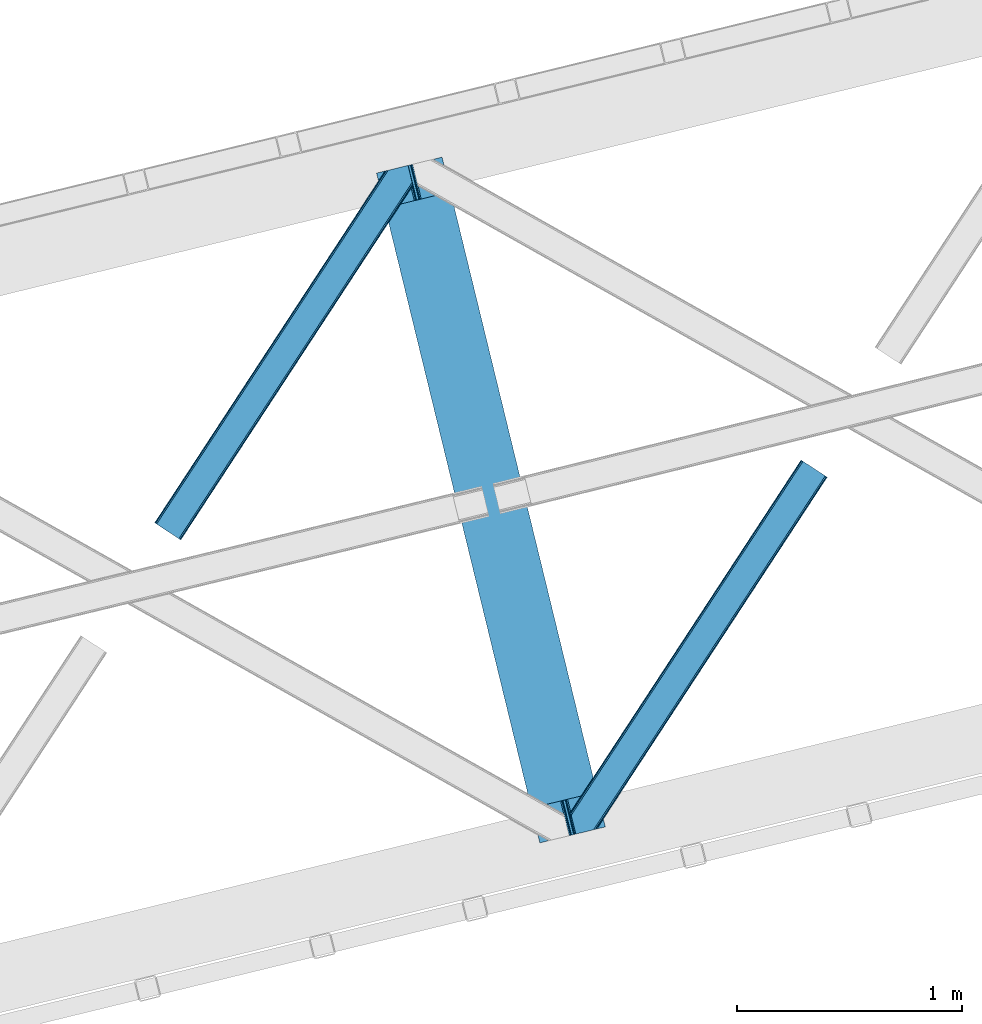
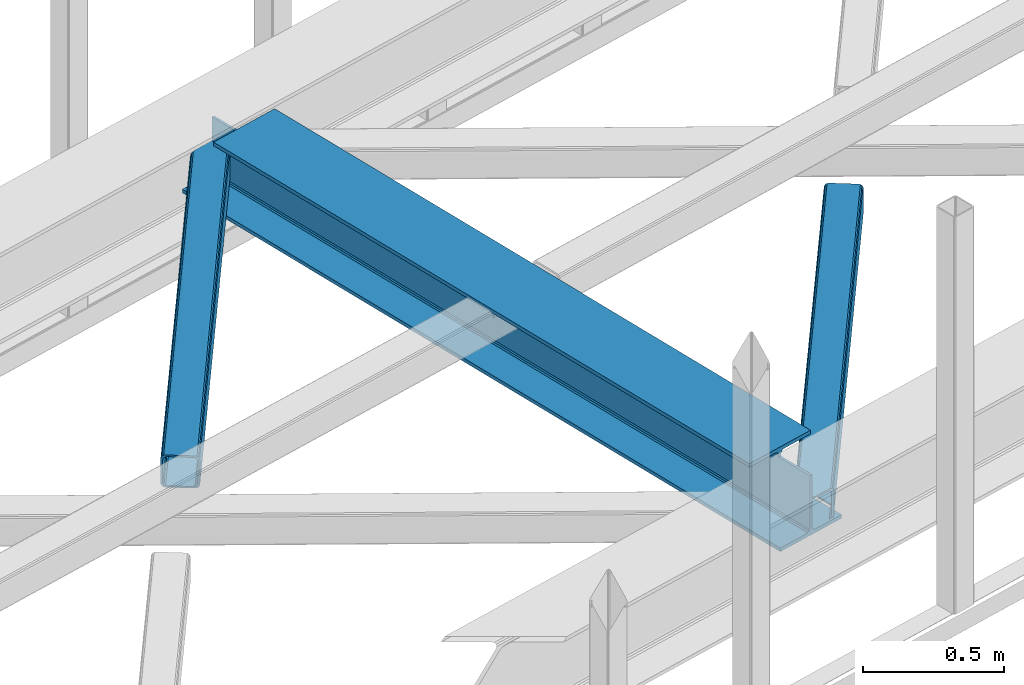
# One storey, part 33 of 67: 2 members, 1 beam.
"""IFC4 building model written with IfcOpenShell, lengths in millimetres."""

from ifc_helpers import new_model, entity, si_unit, converted_unit, derived_unit, direction, frame, origin, place, context, subcontext, project, spatial, triangles, polygons, material, type_object, element, save


model = new_model("IFC4")

# Units and contexts
model_context = context("Model", 3, precision=0.01, world=origin(), true_north=direction((6.12303176911189e-17, 1.0)))
plan_context = context("Plan", 3, precision=0.01, world=origin(), true_north=direction((6.12303176911189e-17, 1.0)))
body_context = subcontext(model_context, "Body", "Model", "MODEL_VIEW")
ifc_project = project(units=[si_unit("LENGTHUNIT", "METRE", prefix="MILLI"), si_unit("AREAUNIT", "SQUARE_METRE"), si_unit("VOLUMEUNIT", "CUBIC_METRE"), converted_unit("PLANEANGLEUNIT", "DEGREE", entity("IfcRatioMeasure", 0.0174532925199433), si_unit("PLANEANGLEUNIT", "RADIAN"), dimensions=[0, 0, 0, 0, 0, 0, 0]), si_unit("MASSUNIT", "GRAM", prefix="KILO"), derived_unit("MASSDENSITYUNIT", [(si_unit("MASSUNIT", "GRAM", prefix="KILO"), 1), (si_unit("LENGTHUNIT", "METRE"), -3)]), derived_unit("MOMENTOFINERTIAUNIT", [(si_unit("LENGTHUNIT", "METRE"), 4)]), si_unit("TIMEUNIT", "SECOND"), si_unit("FREQUENCYUNIT", "HERTZ"), si_unit("THERMODYNAMICTEMPERATUREUNIT", "DEGREE_CELSIUS"), derived_unit("THERMALTRANSMITTANCEUNIT", [(si_unit("MASSUNIT", "GRAM", prefix="KILO"), 1), (si_unit("THERMODYNAMICTEMPERATUREUNIT", "KELVIN"), -1), (si_unit("TIMEUNIT", "SECOND"), -3)]), derived_unit("VOLUMETRICFLOWRATEUNIT", [(si_unit("LENGTHUNIT", "METRE"), 3), (si_unit("TIMEUNIT", "SECOND"), -1)]), derived_unit("MASSFLOWRATEUNIT", [(si_unit("MASSUNIT", "GRAM", prefix="KILO"), 1), (si_unit("TIMEUNIT", "SECOND"), -1)]), derived_unit("ROTATIONALFREQUENCYUNIT", [(si_unit("TIMEUNIT", "SECOND"), -1)]), si_unit("ELECTRICCURRENTUNIT", "AMPERE"), si_unit("ELECTRICVOLTAGEUNIT", "VOLT"), si_unit("POWERUNIT", "WATT"), si_unit("FORCEUNIT", "NEWTON", prefix="KILO"), si_unit("ILLUMINANCEUNIT", "LUX"), si_unit("LUMINOUSFLUXUNIT", "LUMEN"), si_unit("LUMINOUSINTENSITYUNIT", "CANDELA"), derived_unit("USERDEFINED", [(si_unit("MASSUNIT", "GRAM", prefix="KILO"), -1), (si_unit("LENGTHUNIT", "METRE"), -2), (si_unit("TIMEUNIT", "SECOND"), 3), (si_unit("LUMINOUSFLUXUNIT", "LUMEN"), 1)]), derived_unit("LINEARVELOCITYUNIT", [(si_unit("LENGTHUNIT", "METRE"), 1), (si_unit("TIMEUNIT", "SECOND"), -1)]), si_unit("PRESSUREUNIT", "PASCAL"), derived_unit("USERDEFINED", [(si_unit("LENGTHUNIT", "METRE"), -2), (si_unit("MASSUNIT", "GRAM", prefix="KILO"), 1), (si_unit("TIMEUNIT", "SECOND"), -2)]), derived_unit("LINEARFORCEUNIT", [(si_unit("MASSUNIT", "GRAM", prefix="KILO"), 1), (si_unit("LENGTHUNIT", "METRE"), 1), (si_unit("TIMEUNIT", "SECOND"), -2), (si_unit("LENGTHUNIT", "METRE"), -1)]), derived_unit("PLANARFORCEUNIT", [(si_unit("MASSUNIT", "GRAM", prefix="KILO"), 1), (si_unit("LENGTHUNIT", "METRE"), 1), (si_unit("TIMEUNIT", "SECOND"), -2), (si_unit("LENGTHUNIT", "METRE"), -2)])], contexts=[model_context, plan_context])

# Site, building, storey
site_placement = place(None, origin())
site = spatial("IfcSite", under=ifc_project, at=site_placement, CompositionType="ELEMENT")
building_placement = place(site_placement, origin())
building = spatial("IfcBuilding", under=site, at=building_placement, CompositionType="ELEMENT")
storey_placement = place(building_placement, frame((0.0, 0.0, 19800.0)))
storey = spatial("IfcBuildingStorey", under=building, at=storey_placement, CompositionType="ELEMENT", Elevation=19800.0)

# Beam
ifc_material = material(Name="Metal painted (White)")
beam_type = type_object("IfcBeamType", PredefinedType="BEAM")
beam_placement = place(storey_placement, frame((-36668.6903596442, 8856.54799038463, 3808.0)))
element("IfcBeam", 1, at=beam_placement, inside=storey, type_object=beam_type, material=ifc_material, ObjectType="Steel Beam", PredefinedType="BEAM", context=body_context, shape_type="Tessellation", body=[
    polygons([(1018.16648378329, 71.0478278970989, 15.5000000000051), (1018.16648378329, 71.047827897101, 0.0), (291.465617442442, 3052.25531830421, 0.0), (291.465617442442, 3052.25531830421, 15.5000000000051), (894.779372399325, 40.9709140873259, 15.5000000000051), (168.078506058478, 3022.17840449444, 15.5000000000051), (888.087028625366, 39.339584488821, 16.8701684148028), (161.386162284515, 3020.54707489593, 16.8701684148028), (882.413533524746, 37.9566100336497, 20.7720779386478), (155.7126671839, 3019.16410044076, 20.7720779386478), (878.622625296176, 37.0325360459173, 26.6116982174338), (151.921758955325, 3018.24002645303, 26.6116982174338), (877.291435352775, 36.7080444135018, 33.500000000001), (150.590569011928, 3017.91553482061, 33.500000000001), (140.875048430514, 3015.54727389071, 33.500000000001), (140.875048430518, 3015.54727389071, 259.000000000006), (150.590569011928, 3017.91553482061, 259.000000000006), (0.0, 2981.20749040711, 4.33146851719357e-12), (0.0, 2981.20749040711, 15.5000000000051), (123.387111383968, 3011.28440421688, 15.5000000000051), (130.079455157922, 3012.91573381539, 16.8701684148028), (135.752950258546, 3014.29870827056, 20.7720779386478), (139.543858487122, 3015.22278225829, 26.6116982174338), (877.291435352775, 36.7080444135018, 259.000000000006), (867.57591477136, 34.3397834836003, 259.000000000006), (867.57591477136, 34.3397834835981, 33.500000000001), (866.244724827968, 34.0152918511837, 26.6116982174338), (862.453816599393, 33.0912178634492, 20.7720779386478), (856.780321498777, 31.7082434082767, 16.8701684148028), (850.087977724815, 30.076913809773, 15.5000000000051), (726.700866340847, 0.0, 15.5000000000051), (726.700866340847, 0.0, 4.33146851719357e-12), (839.723099725409, 190.827961666225, 259.069792599954), (188.068298227652, 2864.16742161973, 259.000000000006), (188.291691329497, 2863.25097721476, 259.617303331129), (188.304080173126, 2863.20015298098, 266.500003008253), (839.577920935828, 191.423439609248, 266.500002998871), (839.578271056576, 191.422003304514, 260.000004007593), (830.098162489501, 188.087889491629, 259.00634317046), (829.874792453792, 189.004341089458, 259.617303331129), (829.862403610162, 189.055165323231, 266.500003008253), (178.588562847465, 2860.83187869496, 266.500002998871), (178.588212726713, 2860.8333149997, 260.000004007593), (178.443407068373, 2861.42736381349, 259.076120467494), (178.352777646233, 2861.79916068982, 259.000000000006), (840.909408805751, 191.746709053933, 273.388305639792), (844.699685394443, 192.673374225847, 279.227924098781), (850.372756341981, 194.058088689524, 283.129832400619), (857.064948023115, 195.690042220337, 284.500000377228), (980.451976710954, 225.767295275449, 284.500000138975), (980.450306904298, 225.77414534418, 299.999995328161), (688.984884807028, 154.725516080138, 299.999995890966), (688.98655461368, 154.718666011407, 284.500000701776), (812.373583301528, 184.795919066517, 284.500000463524), (819.066070197671, 186.426661533095, 283.129832461069), (824.739981846423, 187.80792717762, 279.227924137327), (828.531516633419, 188.729430826919, 273.388305663689), (177.257074977538, 2860.50860925028, 273.388305639792), (173.46679838885, 2859.58194407836, 279.227924098781), (167.793727441316, 2858.19722961469, 283.129832400619), (161.101535760182, 2856.56527608387, 284.500000377228), (37.7145070723341, 2826.48802302876, 284.500000138975), (37.7161768789945, 2826.48117296003, 299.999995328161), (329.18159897626, 2897.52980222407, 299.999995890962), (329.179929169609, 2897.5366522928, 284.500000701776), (205.79290048176, 2867.45939923769, 284.500000463524), (199.100413585622, 2865.82865677111, 283.129832461069), (193.426501936866, 2864.44739112659, 279.227924137327), (189.63496714987, 2863.52588747729, 273.388305663689)], [[[1, 2, 3, 4]], [[5, 1, 4, 6]], [[7, 5, 6, 8]], [[9, 7, 8, 10]], [[11, 9, 10, 12]], [[13, 11, 12, 14]], [[15, 16, 17, 14, 12, 10, 8, 6, 4, 3, 18, 19, 20, 21, 22, 23]], [[13, 24, 25, 26, 27, 28, 29, 30, 31, 32, 2, 1, 5, 7, 9, 11]], [[2, 32, 18, 3]], [[32, 31, 19, 18]], [[31, 30, 20, 19]], [[27, 26, 15, 23]], [[28, 27, 23, 22]], [[29, 28, 22, 21]], [[30, 29, 21, 20]], [[33, 24, 13, 14, 17, 34, 35, 36, 37, 38]], [[25, 39, 40, 41, 42, 43, 44, 16, 15, 26]], [[39, 25, 24, 33]], [[45, 34, 17, 16]], [[41, 40, 38, 37, 46, 47, 48, 49, 50, 51, 52, 53, 54, 55, 56, 57]], [[42, 58, 59, 60, 61, 62, 63, 64, 65, 66, 67, 68, 69, 36, 35, 43]], [[46, 37, 36, 69]], [[47, 46, 69, 68]], [[48, 47, 68, 67]], [[49, 48, 67, 66]], [[50, 49, 66, 65]], [[51, 50, 65, 64]], [[52, 51, 64, 63]], [[53, 52, 63, 62]], [[54, 53, 62, 61]], [[55, 54, 61, 60]], [[56, 55, 60, 59]], [[57, 56, 59, 58]], [[41, 57, 58, 42]]], closed=False),
])

# Members
member_type_1 = type_object("IfcMemberType", PredefinedType="BRACE")
member_1_placement = place(storey_placement, frame((-37656.9014648438, 10204.5515441895, 3823.99987792968)))
element("IfcMember", 2, at=member_1_placement, inside=storey, type_object=member_type_1, ObjectType="Steel Horizontal Brace", PredefinedType="BRACE", context=body_context, shape_type="Tessellation", body=[
    triangles([(994.774163818358, 1564.02662658691, 0.0), (1028.82324829102, 1424.34678039551, 0.0), (14.643292236331, 67.1040435791019, 0.0), (102.486767578128, 9.58662414550781, 0.0), (1.1162109375, 75.9604797363281, 10.8039916992202), (0.0, 76.6895050048824, 17.5012573242202), (1025.02813110351, 1642.17883300781, 17.5012573242202), (4.29043579101563, 73.8826995849613, 5.12526855468968), (990.476751708986, 1585.87645568848, 9.49942016601563), (990.046545410158, 1584.44747314453, 8.74132690429906), (989.90701904297, 1583.99168701172, 8.49948120117188), (990.762780761717, 1580.48841247559, 5.12526855468968), (1027.31171264649, 1642.73461303711, 10.8691040039084), (1027.78377685547, 1642.84972229004, 9.49942016601563), (992.602203369141, 1572.93538513184, 1.33247680664135), (9.04130859374709, 70.7724243164066, 1.33247680664135), (1025.02813110351, 1642.17883300781, 122.499499511719), (0.0, 76.6895050048824, 122.499499511719), (1026.92336425781, 1642.64043273926, 129.196765136719), (1.1162109375, 75.9604797363281, 129.196765136719), (1032.31838378906, 1643.95546875, 134.87548828125), (4.29043579101563, 73.8826995849613, 134.87548828125), (1040.39463500977, 1645.92395324707, 138.668280029298), (9.04130859374709, 70.7724243164066, 138.668280029298), (1049.91963500976, 1648.24590454102, 140.00075683594), (14.643292236331, 67.1040435791019, 140.00075683594), (994.871832275392, 1567.85081176758, 9.49942016601563), (994.762536621092, 1567.00667724609, 9.2947814941399), (994.650915527345, 1566.15091552734, 9.08781738281323), (994.541619873045, 1565.30561828613, 8.8831787109375), (994.746258544925, 1564.1440612793, 8.49948120117188), (1047.05469360352, 1647.54827270508, 9.49942016601563), (14.8967651367202, 66.9377746582031, 8.3320495605476), (20.4987487792969, 63.2693939208984, 6.99957275390625), (997.043792724609, 1554.71440429688, 6.99957275390625), (10.1458923339815, 70.0480499267578, 12.1248413085959), (1042.27591552735, 1646.38322753906, 12.1248413085959), (1036.87857055664, 1645.06702880859, 17.8035644531265), (1034.9856628418, 1644.60542907715, 24.5008300781265), (6.97166748046584, 72.1258300781246, 17.8035644531265), (5.85778198242042, 72.8548553466808, 24.5008300781265), (1026.55361938477, 1433.65900268555, 6.99957275390625), (96.6313110351548, 13.420111083984, 6.99957275390625), (1028.71860351563, 1424.77582397461, 8.41343994140698), (1032.83695678711, 1407.88615722656, 5.12526855468968), (1033.6903930664, 1404.3817199707, 8.49948120117188), (1030.99520874023, 1415.43918457031, 1.33247680664135), (1034.9856628418, 1644.60542907715, 115.499926757813), (5.85778198242042, 72.8548553466808, 115.499926757813), (1050.34984130859, 1648.35171203613, 131.668707275392), (1059.87716674805, 1650.67366333008, 133.001184082033), (20.4987487792969, 63.2693939208984, 133.001184082033), (14.8967651367202, 66.9377746582031, 131.668707275392), (1042.27591552735, 1646.38322753906, 127.873590087893), (10.1458923339815, 70.0480499267578, 127.873590087893), (1036.87857055664, 1645.06702880859, 122.197192382813), (6.97166748046584, 72.1258300781246, 122.197192382813), (1128.10788574219, 1667.30520629883, 140.00075683594), (1128.10788574219, 1667.30520629883, 133.001184082033), (1144.33015136719, 1600.75810546875, 140.00075683594), (102.486767578128, 9.58662414550781, 140.00075683594), (1142.06052246094, 1610.06916503906, 133.001184082033), (96.6313110351548, 13.420111083984, 133.001184082033), (1146.50211181641, 1591.84934692383, 138.668280029298), (108.088751220705, 5.91708068847765, 138.668280029298), (1148.34385986328, 1584.29631958008, 134.87548828125), (112.839624023436, 2.80796813964844, 134.87548828125), (1149.57401733399, 1579.2501159668, 129.196765136719), (116.013848876952, 0.729025268554324, 129.196765136719), (1150.00422363282, 1577.47813110352, 122.499499511719), (117.127734374997, 0.0, 122.499499511719), (1150.00422363282, 1577.47813110352, 17.5012573242202), (117.127734374997, 0.0, 17.5012573242202), (106.98416748047, 6.64261779785193, 127.873590087893), (110.156066894531, 4.56367492675781, 122.197192382813), (111.269952392577, 3.83464965820349, 115.499926757813), (102.233294677731, 9.75173034667932, 131.668707275392), (116.013848876952, 0.729025268554324, 10.8039916992202), (106.98416748047, 6.64261779785193, 12.1248413085959), (112.839624023436, 2.80796813964844, 5.12526855468968), (111.269952392577, 3.83464965820349, 24.5008300781265), (110.156066894531, 4.56367492675781, 17.8035644531265), (108.088751220705, 5.91708068847765, 1.33247680664135), (102.233294677731, 9.75173034667932, 8.3320495605476), (1147.30438842774, 1588.56233825684, 122.197192382813), (1147.73459472656, 1586.78919067383, 115.499926757813), (1146.07423095703, 1593.60854187012, 127.873590087893), (1144.23248291016, 1601.16040649414, 131.668707275392), (1147.73459472656, 1586.78919067383, 24.5008300781265), (1147.21602172851, 1588.9239440918, 17.8686767578147), (1149.994921875, 1577.51650085449, 16.5013183593765), (1147.10672607422, 1589.36461486816, 16.5013183593765), (1145.27893066406, 1573.10863037109, 10.8714294433594), (1034.62056884765, 1404.78750915527, 9.49942016601563), (1144.12783813477, 1572.03427734375, 9.49942016601563), (1142.79303588867, 1588.59721984863, 12.1248413085959), (1030.22548828125, 1422.8143157959, 9.49942016601563), (1029.19764404297, 1423.6724029541, 8.80643920898365), (1139.73275756836, 1590.05992126465, 9.49942016601563)], [[1, 2, 3], [4, 3, 2], [5, 6, 7], [8, 9, 10], [11, 12, 8], [5, 13, 9], [9, 8, 5], [13, 14, 9], [15, 1, 16], [3, 16, 1], [12, 15, 8], [16, 8, 15], [7, 13, 5], [17, 7, 6], [6, 18, 17], [19, 17, 20], [18, 20, 17], [21, 19, 22], [20, 22, 19], [23, 21, 24], [22, 24, 21], [25, 23, 26], [24, 26, 23], [27, 28, 9], [28, 29, 10], [29, 30, 10], [30, 31, 11], [14, 32, 27], [27, 9, 14], [33, 34, 35], [36, 33, 31], [31, 30, 36], [28, 36, 29], [28, 27, 36], [36, 30, 29], [32, 37, 27], [36, 27, 37], [35, 31, 33], [38, 39, 40], [41, 40, 39], [37, 38, 36], [40, 36, 38], [42, 35, 34], [34, 43, 42], [1, 35, 42], [31, 12, 11], [1, 31, 35], [31, 15, 12], [31, 1, 15], [2, 1, 42], [44, 2, 42], [45, 44, 46], [44, 47, 2], [44, 45, 47], [39, 48, 49], [49, 41, 39], [50, 51, 52], [52, 53, 50], [54, 50, 53], [53, 55, 54], [56, 54, 55], [55, 57, 56], [48, 56, 57], [57, 49, 48], [56, 17, 19], [50, 23, 25], [58, 51, 25], [51, 58, 59], [51, 50, 25], [54, 23, 50], [54, 56, 21], [21, 23, 54], [19, 21, 56], [39, 7, 17], [37, 14, 38], [56, 48, 17], [37, 32, 14], [39, 38, 7], [48, 39, 17], [13, 7, 38], [38, 14, 13], [60, 25, 61], [25, 60, 58], [26, 61, 25], [51, 62, 63], [51, 59, 62], [63, 52, 51], [64, 60, 61], [61, 65, 64], [66, 64, 65], [65, 67, 66], [68, 66, 67], [67, 69, 68], [70, 68, 69], [69, 71, 70], [72, 70, 71], [71, 73, 72], [69, 74, 75], [76, 73, 71], [69, 75, 71], [69, 67, 74], [75, 76, 71], [74, 67, 65], [63, 61, 26], [61, 77, 65], [77, 61, 63], [77, 74, 65], [78, 79, 80], [81, 73, 76], [73, 82, 78], [82, 73, 81], [78, 82, 79], [4, 43, 3], [83, 80, 79], [79, 84, 83], [84, 43, 4], [4, 83, 84], [55, 24, 22], [26, 52, 63], [26, 53, 52], [53, 26, 24], [55, 53, 24], [49, 18, 6], [20, 57, 55], [22, 20, 55], [57, 20, 18], [49, 57, 18], [16, 36, 8], [3, 43, 34], [34, 33, 3], [33, 36, 16], [16, 3, 33], [5, 8, 36], [6, 41, 49], [40, 6, 5], [6, 40, 41], [40, 5, 36], [85, 86, 75], [76, 75, 86], [87, 85, 74], [75, 74, 85], [88, 87, 77], [74, 77, 87], [62, 88, 63], [77, 63, 88], [86, 89, 76], [81, 76, 89], [90, 91, 92], [70, 72, 89], [72, 90, 89], [89, 86, 70], [72, 91, 90], [85, 70, 86], [68, 70, 85], [66, 85, 87], [85, 66, 68], [87, 64, 66], [88, 64, 87], [88, 62, 60], [88, 60, 64], [62, 58, 60], [62, 59, 58], [73, 78, 93], [93, 72, 73], [94, 93, 78], [94, 95, 93], [80, 45, 46], [46, 78, 80], [46, 94, 78], [47, 45, 83], [80, 83, 45], [2, 47, 4], [83, 4, 47], [93, 91, 72], [82, 81, 89], [82, 92, 96], [82, 90, 92], [84, 97, 98], [79, 96, 97], [97, 84, 79], [96, 99, 97], [43, 84, 44], [44, 42, 43], [96, 79, 82], [89, 90, 82], [96, 91, 93], [96, 92, 91], [96, 95, 99], [93, 95, 96], [99, 95, 97], [94, 97, 95]]),
])
member_type_2 = type_object("IfcMemberType", PredefinedType="BRACE")
member_2_placement = place(storey_placement, frame((-35805.5772583008, 8895.6233001709, 3823.99987792968)))
element("IfcMember", 3, at=member_2_placement, inside=storey, type_object=member_type_2, ObjectType="Steel Horizontal Brace", PredefinedType="BRACE", context=body_context, shape_type="Tessellation", body=[
    triangles([(109.770043945318, 259.949830627442, 7.52047119140843), (115.030187988283, 238.365682983398, 7.77626953125218), (114.216284179689, 239.946981811523, 8.3320495605476), (108.809637451173, 259.662638854981, 8.52041015625218), (113.637249755862, 239.859777832031, 8.52041015625218), (112.20710449219, 237.677352905273, 8.52041015625218), (91.0339782714873, 232.516621398925, 8.52041015625218), (109.535174560551, 237.025648498535, 9.49942016601563), (90.2619323730469, 232.328260803222, 9.49942016601563), (5.0206237793027, 77.405158996582, 9.49942016601563), (0.625543212896446, 95.4308029174808, 9.49942016601563), (1046.62216186523, 1651.75382995605, 6.99957275390625), (1041.02017822266, 1655.42221069336, 8.3320495605476), (116.699853515631, 231.514938354492, 6.99957275390625), (1036.26930541993, 1658.53132324219, 12.1248413085959), (3.92999267578125, 81.8752349853512, 12.1248413085959), (1033.09740600587, 1660.61026611328, 17.8035644531265), (2.69983520507958, 86.9220199584961, 17.8035644531265), (1031.98352050781, 1661.34045410156, 24.5008300781265), (2.26962890625146, 88.6940048217766, 24.5008300781265), (1122.7547241211, 1601.90454711914, 6.99957275390625), (146.209680175787, 110.459536743165, 6.99957275390625), (1031.98352050781, 1661.34045410156, 115.499926757813), (2.26962890625146, 88.6940048217766, 115.499926757813), (1033.09740600587, 1660.61026611328, 122.197192382813), (2.69983520507958, 86.9220199584961, 122.197192382813), (1036.26930541993, 1658.53132324219, 127.873590087893), (3.92999267578125, 81.8752349853512, 127.873590087893), (1041.02017822266, 1655.42221069336, 131.668707275392), (5.77174072265916, 74.3227890014641, 131.668707275392), (1046.62216186523, 1651.75382995605, 133.001184082033), (7.94370117187646, 65.4140304565426, 133.001184082033), (1027.24194946289, 1664.44491577148, 10.8039916992202), (0.518572998051241, 95.8714736938473, 10.8691040039084), (0.0, 98.0056457519531, 17.5012573242202), (1035.16472167969, 1659.25686035156, 1.33247680664135), (112.260589599609, 249.73533782959, 1.33247680664135), (110.544415283206, 256.772117614746, 5.59500732422021), (109.077062988283, 259.839372253418, 8.32042236328198), (1030.41384887695, 1662.36597290039, 5.12526855468968), (1040.76670532227, 1655.58847961426, 0.0), (114.430224609379, 240.826579284669, 0.0), (1026.12573852539, 1665.17394104004, 17.5012573242202), (1128.61250610352, 1598.06989746094, 0.0), (148.479309082031, 101.147314453125, 0.0), (150.651269531256, 92.2385559082031, 1.33247680664135), (148.507214355472, 101.029298400879, 8.49948120117188), (152.493017578126, 84.686109924316, 5.12526855468968), (153.346453857426, 81.182254028321, 8.49948120117188), (1026.12573852539, 1665.17394104004, 122.499499511719), (0.0, 98.0056457519531, 122.499499511719), (1040.76670532227, 1655.58847961426, 140.00075683594), (1035.16472167969, 1659.25686035156, 138.668280029298), (3.50211181640771, 83.6350112915043, 138.668280029298), (5.674072265625, 74.7256713867191, 140.00075683594), (1030.41384887695, 1662.36597290039, 134.87548828125), (1.66036376953707, 91.1874572753914, 134.87548828125), (1027.24194946289, 1664.44491577148, 129.196765136719), (0.430206298828125, 96.2336608886726, 129.196765136719), (23.8892395019575, 0.0, 140.00075683594), (23.8892395019575, 0.0, 133.001184082033), (1128.61250610352, 1598.06989746094, 140.00075683594), (93.3338378906265, 16.9280364990227, 140.00075683594), (1122.7547241211, 1601.90454711914, 133.001184082033), (83.3786315917969, 14.5008590698235, 133.001184082033), (1143.2534729004, 1588.48443603516, 122.499499511719), (1142.1372619629, 1589.21346130371, 129.196765136719), (118.225341796875, 22.9951080322262, 122.499499511719), (116.330108642578, 22.5335083007813, 129.196765136719), (1138.96536254883, 1591.29124145508, 134.87548828125), (110.935089111328, 21.2178909301765, 134.87548828125), (1134.2144897461, 1594.40151672363, 138.668280029298), (102.861163330082, 19.2499877929695, 138.668280029298), (1143.2534729004, 1588.48443603516, 17.5012573242202), (118.225341796875, 22.9951080322262, 17.5012573242202), (1142.1372619629, 1589.21346130371, 10.8039916992202), (1133.10758056641, 1595.12589111328, 12.1248413085959), (1136.28180541992, 1593.04811096191, 17.8035644531265), (1137.39569091797, 1592.31792297363, 24.5008300781265), (1138.96536254883, 1591.29124145508, 5.12526855468968), (1134.2144897461, 1594.40151672363, 1.33247680664135), (1128.35903320313, 1598.23616638184, 8.3320495605476), (1133.10758056641, 1595.12589111328, 127.873590087893), (1137.39569091797, 1592.31792297363, 115.499926757813), (1136.28180541992, 1593.04811096191, 122.197192382813), (1128.35903320313, 1598.23616638184, 131.668707275392), (92.9036315917983, 16.8228103637703, 131.668707275392), (100.977557373051, 18.7912948608391, 127.873590087893), (106.372576904301, 20.106330871582, 122.197192382813), (108.267810058598, 20.5685119628906, 115.499926757813), (108.267810058598, 20.5685119628906, 24.5008300781265), (100.977557373051, 18.7912948608391, 12.1248413085959), (115.472021484376, 22.32421875, 9.49942016601563), (106.372576904301, 20.106330871582, 17.8035644531265), (96.1987792968794, 17.6262496948239, 9.49942016601563), (115.944085693365, 22.439328002929, 10.8691040039084), (153.060424804688, 80.2392883300781, 8.99945068359375), (152.776721191411, 79.2969039916989, 9.49942016601563), (148.711853027344, 99.8677413940422, 8.8831787109375), (148.602557373051, 99.023606872559, 9.08781738281323), (148.490936279297, 98.1666824340828, 9.2947814941399), (148.381640625004, 97.3231292724613, 9.49942016601563)], [[1, 2, 3], [4, 5, 6], [6, 7, 4], [7, 6, 8], [8, 9, 7], [9, 8, 10], [10, 11, 9], [12, 13, 3], [3, 2, 12], [2, 14, 12], [15, 16, 8], [8, 13, 15], [8, 5, 13], [16, 10, 8], [8, 6, 5], [15, 17, 18], [18, 16, 15], [17, 19, 20], [20, 18, 17], [21, 12, 14], [14, 22, 21], [19, 23, 20], [24, 20, 23], [23, 25, 24], [26, 24, 25], [25, 27, 26], [28, 26, 27], [27, 29, 28], [30, 28, 29], [29, 31, 30], [32, 30, 31], [33, 34, 35], [36, 37, 38], [33, 4, 9], [33, 1, 39], [9, 34, 33], [9, 11, 34], [4, 7, 9], [40, 38, 1], [1, 33, 40], [38, 40, 36], [36, 41, 37], [42, 37, 41], [35, 43, 33], [41, 44, 42], [45, 42, 44], [14, 42, 22], [37, 2, 38], [2, 37, 42], [38, 2, 1], [42, 14, 2], [22, 42, 45], [46, 47, 45], [47, 46, 48], [45, 47, 22], [48, 49, 47], [50, 43, 35], [35, 51, 50], [52, 53, 54], [54, 55, 52], [53, 56, 57], [57, 54, 53], [56, 58, 59], [59, 57, 56], [58, 50, 51], [51, 59, 58], [28, 57, 26], [30, 32, 55], [32, 60, 55], [32, 61, 60], [54, 30, 55], [28, 54, 57], [16, 11, 10], [28, 30, 54], [51, 35, 20], [24, 26, 51], [24, 51, 20], [57, 59, 26], [26, 59, 51], [35, 18, 20], [18, 11, 16], [11, 18, 34], [35, 34, 18], [62, 55, 63], [62, 52, 55], [55, 60, 63], [64, 32, 31], [32, 64, 65], [61, 32, 65], [66, 67, 68], [69, 68, 67], [67, 70, 69], [71, 69, 70], [70, 72, 71], [73, 71, 72], [72, 62, 73], [63, 73, 62], [74, 66, 75], [68, 75, 66], [76, 77, 78], [79, 66, 74], [76, 78, 74], [76, 80, 77], [78, 79, 74], [77, 80, 81], [21, 44, 41], [44, 82, 81], [82, 44, 21], [82, 77, 81], [67, 83, 70], [84, 66, 79], [66, 85, 67], [85, 66, 84], [67, 85, 83], [62, 64, 52], [72, 70, 83], [83, 86, 72], [86, 64, 62], [62, 72, 86], [15, 36, 40], [41, 12, 21], [41, 13, 12], [13, 41, 36], [15, 13, 36], [19, 43, 50], [33, 17, 15], [40, 33, 15], [17, 33, 43], [19, 17, 43], [53, 27, 56], [52, 64, 31], [31, 29, 52], [29, 27, 53], [53, 52, 29], [58, 56, 27], [50, 23, 19], [25, 50, 58], [50, 25, 23], [25, 58, 27], [64, 86, 87], [87, 65, 64], [86, 83, 88], [88, 87, 86], [83, 85, 89], [89, 88, 83], [85, 84, 90], [90, 89, 85], [84, 79, 91], [91, 90, 84], [89, 68, 69], [87, 73, 63], [60, 65, 63], [65, 60, 61], [65, 87, 63], [88, 73, 87], [88, 89, 71], [71, 73, 88], [69, 71, 89], [91, 75, 68], [92, 93, 94], [89, 90, 68], [92, 95, 93], [91, 94, 75], [90, 91, 68], [96, 75, 94], [94, 93, 96], [76, 74, 75], [49, 80, 97], [98, 97, 80], [49, 48, 80], [76, 96, 98], [98, 80, 76], [96, 93, 98], [44, 81, 45], [46, 45, 81], [81, 80, 46], [48, 46, 80], [75, 96, 76], [82, 21, 22], [77, 82, 47], [47, 99, 77], [77, 100, 101], [100, 77, 99], [101, 102, 77], [77, 102, 92], [95, 92, 102], [22, 47, 82], [79, 78, 91], [94, 91, 78], [78, 77, 94], [92, 94, 77], [102, 101, 98], [101, 100, 97], [100, 99, 49], [99, 47, 49], [102, 98, 93], [93, 95, 102]]),
])

save(model, "model.ifc")
